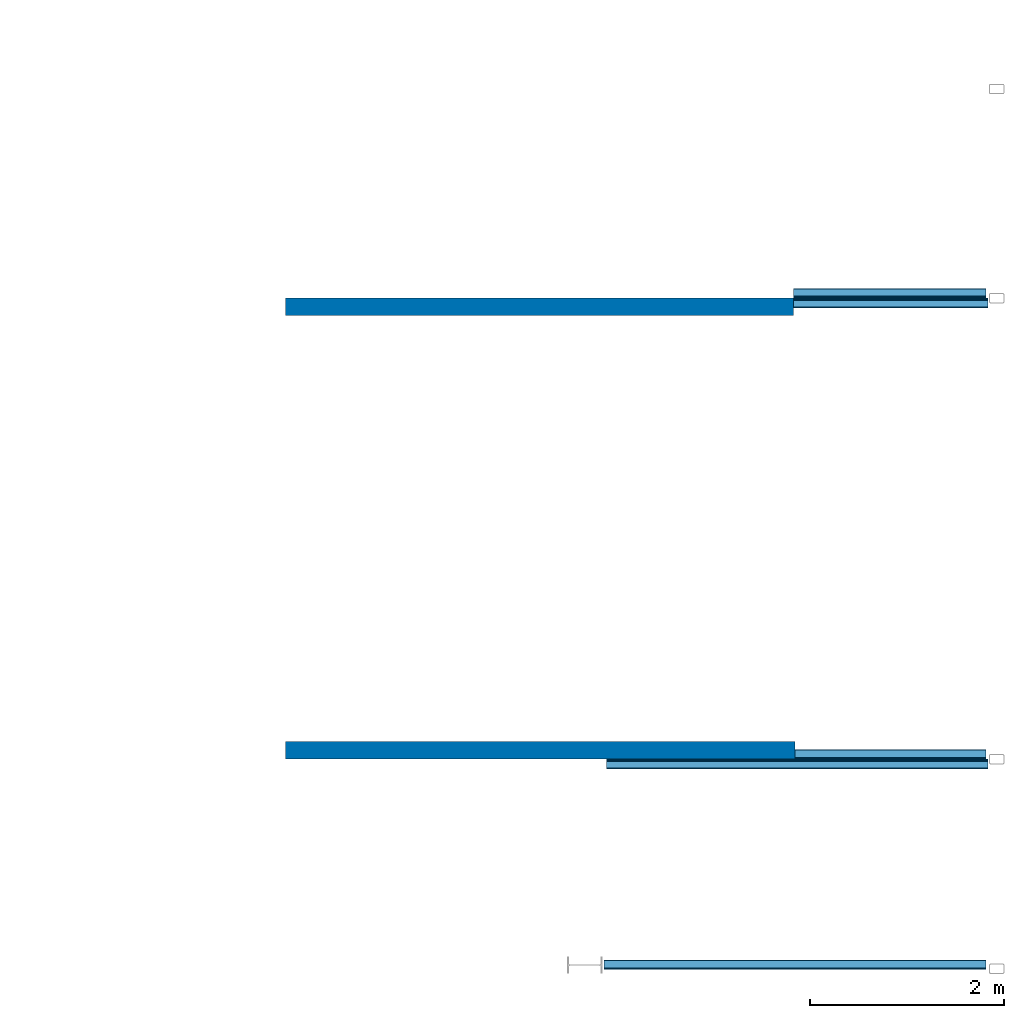
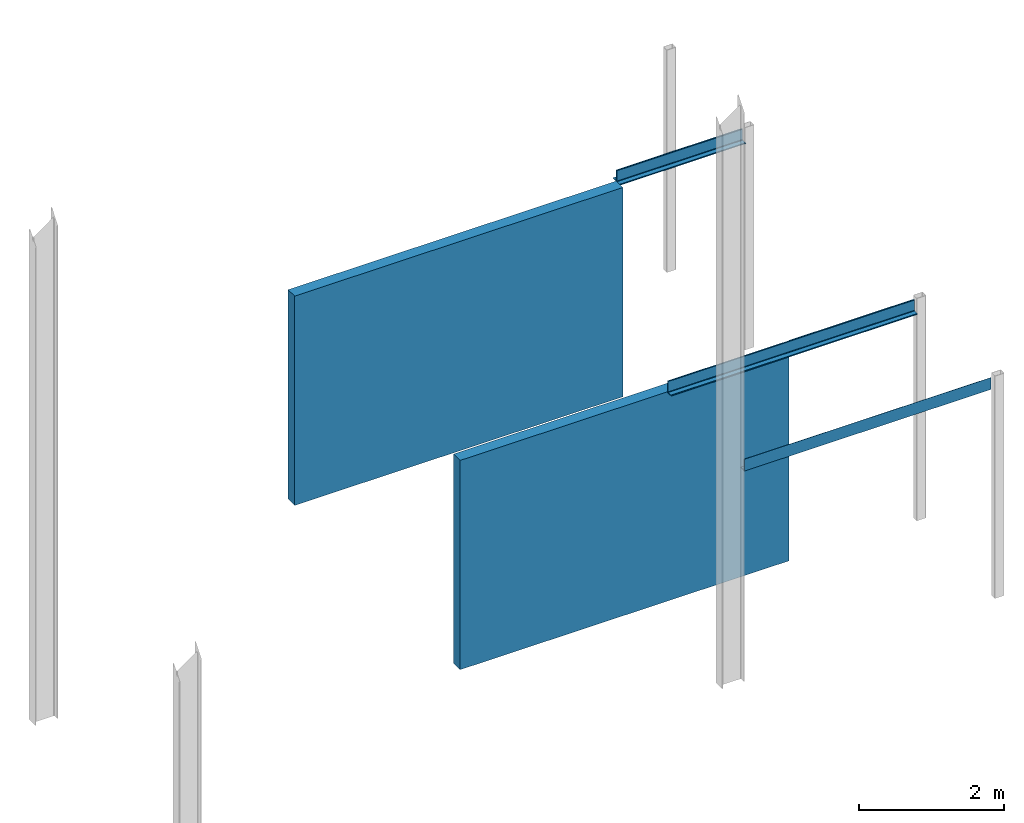
# One storey, part 4 of 4: 5 beams, 2 walls.
"""IFC2X3 building model written with IfcOpenShell, lengths in millimetres."""

from ifc_helpers import new_model, entity, si_unit, converted_unit, frame, frame_2d, origin, place, context, project, spatial, polyline, circle_curve, parameter, trimmed, segment, composite_curve, rectangle, outline, extrude, clip, bounded_halfspace, material, layer, layer_set, layer_usage, element, save


model = new_model("IFC2X3")

# Units and contexts
model_context = context("Model", 3, precision=1e-06, world=origin())
plan_context = context("Plan", 3, precision=1e-06, world=origin())
ifc_project = project(units=[si_unit("LENGTHUNIT", "METRE", prefix="MILLI"), si_unit("AREAUNIT", "SQUARE_METRE", prefix="MILLI"), si_unit("VOLUMEUNIT", "CUBIC_METRE", prefix="MILLI"), converted_unit("PLANEANGLEUNIT", "DEGREE", entity("IfcRatioMeasure", 0.01745329251994328), si_unit("PLANEANGLEUNIT", "RADIAN"), dimensions=[0, 0, 0, 0, 0, 0, 0]), si_unit("TIMEUNIT", "SECOND")], contexts=[model_context, plan_context])

# Site, building, storey
site_placement = place(None, origin())
site = spatial("IfcSite", under=ifc_project, at=site_placement, CompositionType="ELEMENT")
building_placement = place(None, origin())
building = spatial("IfcBuilding", under=site, at=building_placement, CompositionType="ELEMENT")
storey_placement = place(building_placement, origin())
storey = spatial("IfcBuildingStorey", under=building, at=storey_placement, Name="Level 1", CompositionType="ELEMENT", Elevation=0.0)

# Beams
ifc_material_1 = material(Name="Metal - Steel - 345 MPa")
beam_1_placement = place(storey_placement, frame((-12017.18323242538, 7061.098768151644, 3750.0), z_axis=(0.0, 0.0, 1.0), x_axis=(0.0, 1.0, 0.0)))
element("IfcBeam", 1, at=beam_1_placement, inside=storey, material=ifc_material_1, ObjectType="L-Angles:CAI200x100x14", context=model_context, shape_type="SweptSolid", body=[
    extrude(outline(composite_curve([segment(polyline([(-34.57142857142937, -63.14285714285688), (65.42857142857281, -63.14285714285688)]), True, "CONTINUOUS"), segment(trimmed(circle_curve(frame_2d((51.42857142857381, -63.14285714285742), x_axis=(1.0, 0.0)), 14.0), [parameter(1.017777498068326e-13)], [parameter(90.00000000000009)], True, "PARAMETER"), True, "CONTINUOUS"), segment(polyline([(51.42857142857381, -49.14285714285788), (-6.571428571429244, -49.14285714285734)]), True, "CONTINUOUS"), segment(trimmed(circle_curve(frame_2d((-6.571428571428161, -35.14285714285728), x_axis=(1.0, 0.0)), 14.0), [parameter(180.0000000000001)], [parameter(269.9999999999999)], True, "PARAMETER"), False, "CONTINUOUS"), segment(polyline([(-20.57142857142823, -35.14285714285728), (-20.57142857142823, 122.8571428571431)]), True, "CONTINUOUS"), segment(trimmed(circle_curve(frame_2d((-34.57142857142829, 122.8571428571431), x_axis=(1.0, 0.0)), 14.0), [parameter(0.0)], [parameter(90.00000000000024)], True, "PARAMETER"), True, "CONTINUOUS"), segment(polyline([(-34.57142857142829, 136.8571428571432), (-34.57142857142937, -63.14285714285688)]), True, "CONTINUOUS")], self_intersect=False)), frame((34.57142857142829, 1994.442034597584, -170.8571428571376), z_axis=(0.0, -1.0, 0.0), x_axis=(1.0, 0.0, 0.0)), (0.0, 0.0, 1.0), 1981.742033987986),
])
beam_2_placement = place(storey_placement, frame((-14011.62526702297, 7061.098768151647, 3750.0), z_axis=(0.0, 0.0, 1.0), x_axis=(0.0, -1.0, 0.0)))
element("IfcBeam", 2, at=beam_2_placement, inside=storey, material=ifc_material_1, ObjectType="L-Angles:CAI200x100x14", context=model_context, shape_type="SweptSolid", body=[
    extrude(outline(composite_curve([segment(polyline([(-63.14285714285707, -34.57142857142903), (136.857142857143, -34.57142857142903)]), True, "CONTINUOUS"), segment(trimmed(circle_curve(frame_2d((122.8571428571429, -34.57142857142896), x_axis=(0.0, 1.0)), 14.0), [parameter(269.9999999999998)], [parameter(0.0)], True, "PARAMETER"), True, "CONTINUOUS"), segment(polyline([(122.857142857143, -20.57142857142889), (-35.1428571428574, -20.57142857142804)]), True, "CONTINUOUS"), segment(trimmed(circle_curve(frame_2d((-35.14285714285732, -6.571428571427971), x_axis=(0.0, 1.0)), 14.0), [parameter(90.00000000000009)], [parameter(179.9999999999999)], True, "PARAMETER"), False, "CONTINUOUS"), segment(polyline([(-49.14285714285737, -6.571428571428978), (-49.1428571428576, 51.42857142857407)]), True, "CONTINUOUS"), segment(trimmed(circle_curve(frame_2d((-63.14285714285715, 51.42857142857415), x_axis=(0.0, 1.0)), 14.0), [parameter(269.9999999999999)], [parameter(359.9999999999999)], True, "PARAMETER"), True, "CONTINUOUS"), segment(polyline([(-63.14285714285653, 65.42857142857315), (-63.14285714285707, -34.57142857142903)]), True, "CONTINUOUS")], self_intersect=False)), frame((34.57142857142829, 0.0, -170.8571428571376), z_axis=(0.0, 1.0, 0.0), x_axis=(0.0, 0.0, 1.0)), (0.0, 0.0, 1.0), 2006.742034597402),
])
beam_3_placement = place(storey_placement, frame((-12017.18323242539, 2311.098768151621, 3750.0), z_axis=(0.0, 0.0, 1.0), x_axis=(0.0, 1.0, 0.0)))
element("IfcBeam", 3, at=beam_3_placement, inside=storey, material=ifc_material_1, ObjectType="L-Angles:CAI200x100x14", context=model_context, shape_type="SweptSolid", body=[
    extrude(outline(composite_curve([segment(polyline([(-34.5714285714291, -63.14285714285688), (65.42857142857306, -63.14285714285688)]), True, "CONTINUOUS"), segment(trimmed(circle_curve(frame_2d((51.428571428573, -63.14285714285742), x_axis=(0.0, 1.0)), 14.0), [parameter(269.9999999999999)], [parameter(359.9999999999999)], True, "PARAMETER"), True, "CONTINUOUS"), segment(polyline([(51.428571428573, -49.14285714285788), (-6.571428571428971, -49.14285714285734)]), True, "CONTINUOUS"), segment(trimmed(circle_curve(frame_2d((-6.571428571428971, -35.14285714285728), x_axis=(-1.0, 0.0)), 14.0), [parameter(3.562221243239142e-13)], [parameter(90.00000000000009)], True, "PARAMETER"), False, "CONTINUOUS"), segment(polyline([(-20.57142857142904, -35.14285714285728), (-20.5714285714285, 122.8571428571431)]), True, "CONTINUOUS"), segment(trimmed(circle_curve(frame_2d((-34.57142857142856, 122.8571428571431), x_axis=(0.0, 1.0)), 14.0), [parameter(269.9999999999999)], [parameter(1.52666624710249e-13)], True, "PARAMETER"), True, "CONTINUOUS"), segment(polyline([(-34.57142857142856, 136.8571428571432), (-34.5714285714291, -63.14285714285688)]), True, "CONTINUOUS")], self_intersect=False)), frame((34.57142857142883, 1980.0, -170.8571428571376), z_axis=(0.0, -1.0, 0.0), x_axis=(1.0, 0.0, 0.0)), (0.0, 0.0, 1.0), 1967.299999390401),
])
beam_4_placement = place(storey_placement, frame((-14011.62526702298, 2311.098768151623, 3750.0), z_axis=(0.0, 0.0, 1.0), x_axis=(0.0, -1.0, 0.0)))
element("IfcBeam", 4, at=beam_4_placement, inside=storey, material=ifc_material_1, ObjectType="L-Angles:CAI200x100x14", context=model_context, shape_type="SweptSolid", body=[
    extrude(outline(composite_curve([segment(polyline([(-63.14285714285698, -34.57142857142947), (136.8571428571431, -34.57142857142947)]), True, "CONTINUOUS"), segment(trimmed(circle_curve(frame_2d((122.857142857143, -34.57142857142944), x_axis=(1.0, 0.0)), 14.0), [parameter(359.9999999999998)], [parameter(90.00000000000009)], True, "PARAMETER"), True, "CONTINUOUS"), segment(polyline([(122.857142857143, -20.57142857142937), (-35.14285714285734, -20.57142857142948)]), True, "CONTINUOUS"), segment(trimmed(circle_curve(frame_2d((-35.1428571428573, -6.571428571429416), x_axis=(0.0, -1.0)), 14.0), [parameter(269.9999999999999)], [parameter(359.9999999999997)], True, "PARAMETER"), False, "CONTINUOUS"), segment(polyline([(-49.14285714285736, -6.571428571429378), (-49.14285714285774, 51.4285714285726)]), True, "CONTINUOUS"), segment(trimmed(circle_curve(frame_2d((-63.14285714285728, 51.42857142857263), x_axis=(1.0, 0.0)), 14.0), [parameter(1.017777498068326e-13)], [parameter(90.00000000000009)], True, "PARAMETER"), True, "CONTINUOUS"), segment(polyline([(-63.14285714285671, 65.4285714285727), (-63.14285714285698, -34.57142857142947)]), True, "CONTINUOUS")], self_intersect=False)), frame((34.5714285714291, -1925.557965402417, -170.8571428571376), z_axis=(0.0, 1.0, 0.0), x_axis=(0.0, 0.0, 1.0)), (0.0, 0.0, 1.0), 3932.299999999817),
])
beam_5_placement = place(storey_placement, frame((-12017.1832324254, 142.336632009615, 3750.0), z_axis=(0.0, 0.0, 1.0), x_axis=(0.0, 1.0, 0.0)))
element("IfcBeam", 5, at=beam_5_placement, inside=storey, material=ifc_material_1, ObjectType="L-Angles:CAI200x100x14", context=model_context, shape_type="SweptSolid", body=[
    extrude(outline(composite_curve([segment(polyline([(-34.57142857142949, -63.14285714285688), (65.4285714285727, -63.14285714285688)]), True, "CONTINUOUS"), segment(trimmed(circle_curve(frame_2d((51.42857142857273, -63.14285714285742), x_axis=(1.0, 0.0)), 14.0), [parameter(1.017777498068326e-13)], [parameter(90.00000000000009)], True, "PARAMETER"), True, "CONTINUOUS"), segment(polyline([(51.4285714285728, -49.14285714285788), (-6.571428571429273, -49.14285714285734)]), True, "CONTINUOUS"), segment(trimmed(circle_curve(frame_2d((-6.571428571429241, -35.14285714285728), x_axis=(1.0, 0.0)), 14.0), [parameter(180.0000000000001)], [parameter(269.9999999999999)], True, "PARAMETER"), False, "CONTINUOUS"), segment(polyline([(-20.57142857142927, -35.14285714285728), (-20.57142857142873, 122.8571428571431)]), True, "CONTINUOUS"), segment(trimmed(circle_curve(frame_2d((-34.57142857142875, 122.8571428571431), x_axis=(1.0, 0.0)), 14.0), [parameter(0.0)], [parameter(90.00000000000024)], True, "PARAMETER"), True, "CONTINUOUS"), segment(polyline([(-34.57142857142885, 136.8571428571432), (-34.57142857142949, -63.14285714285688)]), True, "CONTINUOUS")], self_intersect=False)), frame((34.57142857142893, 3947.2999993904, -170.8571428571376), z_axis=(0.0, -1.0, 0.0), x_axis=(1.0, 0.0, 0.0)), (0.0, 0.0, 1.0), 3934.5999987808),
])

# Walls
ifc_material_2 = material(Name="Default Wall")
ifc_layer = layer(ifc_material_2, 180.0)
ifc_layer_set = layer_set([ifc_layer], Name="Basic Wall:Generic - 180mm")
ifc_layer_usage_1 = layer_usage(ifc_layer_set, "AXIS2", "POSITIVE", -90.0)
wall_1_placement = place(storey_placement, frame((-19247.18401022489, 6971.098768151646, 0.0)))
element("IfcWallStandardCase", 6, at=wall_1_placement, inside=storey, material=ifc_layer_usage_1, Name="Basic Wall:Generic - 180mm", ObjectType="Basic Wall:Generic - 180mm", context=model_context, shape_type="Clipping", body=[
    clip(extrude(rectangle(XDim=5235.558743201926, YDim=180.0000000000002, at=frame_2d((2617.779371600963, 0.0), x_axis=(-1.0, 0.0))), origin(), (0.0, 0.0, 1.0), 3750.000000000001), bounded_halfspace(frame((0.0, -90.0, 3530.0), z_axis=(0.0, 0.0, 1.0), x_axis=(0.0, 1.0, 0.0)), False, frame((0.0, -90.0, 3530.0)), polyline([(0.0, 0.0), (5235.558743201926, 0.0), (5235.558743201926, 90.0), (5235.558743201925, 180.0), (0.0, 180.0), (0.0, 90.0), (0.0, 0.0)]))),
])
ifc_layer_usage_2 = layer_usage(ifc_layer_set, "AXIS2", "POSITIVE", -90.0)
wall_2_placement = place(storey_placement, frame((-13997.18323242538, 2401.098768151623, 0.0), z_axis=(0.0, 0.0, 1.0), x_axis=(-1.0, 0.0, 0.0)))
element("IfcWallStandardCase", 7, at=wall_2_placement, inside=storey, material=ifc_layer_usage_2, Name="Basic Wall:Generic - 180mm", ObjectType="Basic Wall:Generic - 180mm", context=model_context, shape_type="Clipping", body=[
    clip(clip(clip(extrude(rectangle(XDim=5250.000777799519, YDim=179.9999999999997, at=frame_2d((2625.000388899759, 0.0), x_axis=(-1.0, 0.0))), origin(), (0.0, 0.0, 1.0), 3750.000000000001), bounded_halfspace(frame((0.0, -90.0, 3530.0), z_axis=(0.0, 0.0, -1.0), x_axis=(0.0, 1.0, 0.0)), True, frame((0.0, -90.0, 3530.0)), polyline([(0.0, 0.0), (5250.000777799519, 0.0), (5250.000777799519, 90.0), (0.0, 90.0), (0.0, 0.0)]))), bounded_halfspace(frame((0.0, -90.0, 3530.0), z_axis=(0.0, 0.0, -1.0), x_axis=(0.0, 1.0, 0.0)), True, frame((0.0, -90.0, 3530.0)), polyline([(0.0, 0.0), (5250.000777799519, 0.0), (5250.000777799519, 90.0), (0.0, 90.0), (0.0, 0.0)]))), bounded_halfspace(frame((5250.000777799518, 0.0, 3530.0), z_axis=(0.0, 0.0, 1.0), x_axis=(0.0, 1.0, 0.0)), False, frame((5250.000777799518, 0.0, 3530.0)), polyline([(0.0, 0.0), (0.0, 90.0), (-5250.000777799519, 90.0), (-5250.000777799519, 0.0), (0.0, 0.0)]))),
])

save(model, "model.ifc")
